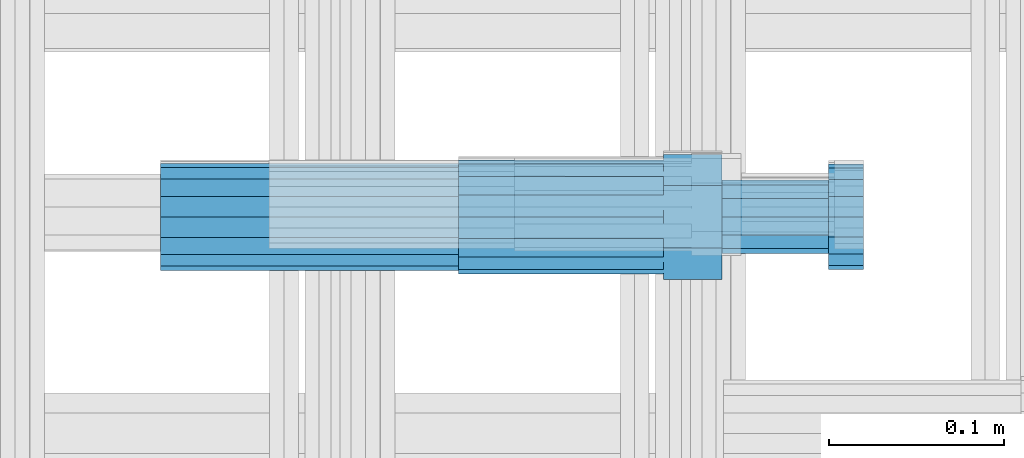
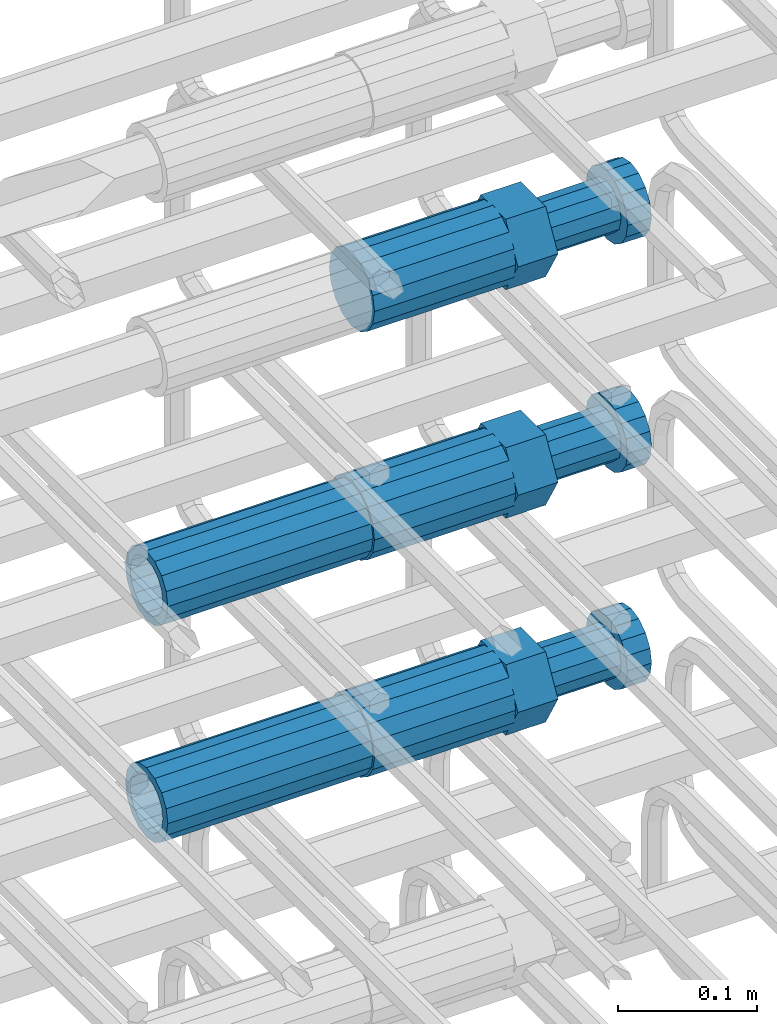
# One storey, part 46 of 177: 5 beams.
"""IFC2X3 building model written with IfcOpenShell, lengths in millimetres."""

from ifc_helpers import new_model, si_unit, frame, origin_with_axes, place, context, subcontext, project, spatial, faceted_brep, material, type_object, element, save


model = new_model("IFC2X3")

# Units and contexts
model_context_1 = context("Model", 3, precision=1e-05, world=origin_with_axes())
model_context_2 = context("Model", 3, precision=1e-05, world=origin_with_axes())
body_context = subcontext(model_context_2, "Body", "Model", "MODEL_VIEW")
ifc_project = project(units=[si_unit("LENGTHUNIT", "METRE", prefix="MILLI"), si_unit("AREAUNIT", "SQUARE_METRE"), si_unit("VOLUMEUNIT", "CUBIC_METRE"), si_unit("MASSUNIT", "GRAM", prefix="KILO"), si_unit("TIMEUNIT", "SECOND"), si_unit("PLANEANGLEUNIT", "RADIAN"), si_unit("SOLIDANGLEUNIT", "STERADIAN"), si_unit("THERMODYNAMICTEMPERATUREUNIT", "DEGREE_CELSIUS"), si_unit("LUMINOUSINTENSITYUNIT", "LUMEN")], contexts=[model_context_1])

# Site, building, storey
site_placement = place(None, origin_with_axes())
site = spatial("IfcSite", under=ifc_project, at=site_placement, CompositionType="ELEMENT")
building_placement = place(site_placement, origin_with_axes())
building = spatial("IfcBuilding", under=site, at=building_placement, Name="Undefined", CompositionType="ELEMENT")
storey_placement = place(building_placement, origin_with_axes())
storey = spatial("IfcBuildingStorey", under=building, at=storey_placement, Name="Undefined", CompositionType="ELEMENT", Elevation=0.0)

# Beams
ifc_material = material(Name="STEEL/S275")
beam_type_1 = type_object("IfcBeamType", PredefinedType="NOTDEFINED")
beam_1_placement = place(storey_placement, frame((2030819.00847313, 6206282.98588032, 21439.9868004324), z_axis=(0.0, 0.0, -1.0), x_axis=(1.0, 0.0, 0.0)))
element("IfcBeam", 1, at=beam_1_placement, inside=storey, type_object=beam_type_1, material=ifc_material, Name="AG40N", context=body_context, shape_type="Brep", body=[
    faceted_brep([(0.0, -23.5000000001164, -9.31322574615479e-10), (0.0, -21.7111690140155, 8.99306066054851), (170.0, -21.7111690140155, 8.99306066054851), (170.0, -23.5, 0.0), (0.0, -16.6170093578839, 16.6170093575493), (170.0, -16.6170093578839, 16.6170093575493), (0.0, -8.99306066057943, 21.7111690137535), (170.0, -8.99306066057943, 21.7111690137535), (0.0, 1.16415321826935e-10, 23.5), (170.0, 0.0, 23.5), (0.0, 8.99306066057943, 21.7111690137535), (170.0, 8.99306066057943, 21.7111690137535), (0.0, 16.6170093578839, 16.6170093575493), (170.0, 16.6170093578839, 16.6170093575493), (0.0, 21.7111690140155, 8.99306066054851), (170.0, 21.7111690140155, 8.99306066054851), (0.0, 23.5000000001164, -9.31322574615479e-10), (170.0, 23.5, 0.0), (0.0, 21.7111690140155, -8.99306066054851), (170.0, 21.7111690140155, -8.99306066054851), (0.0, 16.6170093578839, -16.6170093575493), (170.0, 16.6170093578839, -16.6170093575493), (0.0, 8.99306066057943, -21.7111690137535), (170.0, 8.99306066057943, -21.7111690137535), (0.0, 1.16415321826935e-10, -23.5000000009313), (170.0, 0.0, -23.5), (0.0, -8.99306066057943, -21.7111690137535), (170.0, -8.99306066057943, -21.7111690137535), (0.0, -16.6170093578839, -16.6170093575493), (170.0, -16.6170093578839, -16.6170093575493), (0.0, -21.7111690140155, -8.99306066054851), (170.0, -21.7111690140155, -8.99306066054851), (0.0, -30.5, 0.0), (0.0, -28.1783257415937, -11.6718446873128), (170.0, -28.1783257415937, -11.6718446873128), (170.0, -30.5, 0.0), (0.0, -21.5667568261888, -21.5667568258941), (170.0, -21.5667568261888, -21.5667568258941), (0.0, -11.6718446871346, -28.1783257415518), (170.0, -11.6718446871346, -28.1783257415518), (0.0, 0.0, -30.5), (170.0, 0.0, -30.5), (0.0, 11.6718446871346, -28.1783257415518), (170.0, 11.6718446871346, -28.1783257415518), (0.0, 21.5667568261888, -21.5667568258941), (170.0, 21.5667568261888, -21.5667568258941), (0.0, 28.1783257415937, -11.6718446873128), (170.0, 28.1783257415937, -11.6718446873128), (0.0, 30.5, 0.0), (170.0, 30.5, 0.0), (0.0, 28.1783257415937, 11.6718446873128), (170.0, 28.1783257415937, 11.6718446873128), (0.0, 21.5667568261888, 21.5667568258941), (170.0, 21.5667568261888, 21.5667568258941), (0.0, 11.6718446871346, 28.1783257415518), (170.0, 11.6718446871346, 28.1783257415518), (0.0, 0.0, 30.5), (170.0, 0.0, 30.5), (0.0, -11.6718446871346, 28.1783257415518), (170.0, -11.6718446871346, 28.1783257415518), (0.0, -21.5667568261888, 21.5667568258941), (170.0, -21.5667568261888, 21.5667568258941), (0.0, -28.1783257415937, 11.6718446873128), (170.0, -28.1783257415937, 11.6718446873128)], [[[0, 1, 2, 3]], [[1, 4, 5, 2]], [[4, 6, 7, 5]], [[6, 8, 9, 7]], [[8, 10, 11, 9]], [[10, 12, 13, 11]], [[12, 14, 15, 13]], [[14, 16, 17, 15]], [[16, 18, 19, 17]], [[18, 20, 21, 19]], [[20, 22, 23, 21]], [[22, 24, 25, 23]], [[24, 26, 27, 25]], [[26, 28, 29, 27]], [[28, 30, 31, 29]], [[30, 0, 3, 31]], [[32, 33, 34, 35]], [[33, 36, 37, 34]], [[36, 38, 39, 37]], [[38, 40, 41, 39]], [[40, 42, 43, 41]], [[42, 44, 45, 43]], [[44, 46, 47, 45]], [[46, 48, 49, 47]], [[48, 50, 51, 49]], [[50, 52, 53, 51]], [[52, 54, 55, 53]], [[54, 56, 57, 55]], [[56, 58, 59, 57]], [[58, 60, 61, 59]], [[60, 62, 63, 61]], [[62, 32, 35, 63]], [[37, 39, 41, 43, 45, 47, 49, 51, 53, 55, 57, 59, 61, 63, 35, 34], [5, 7, 9, 11, 13, 15, 17, 19, 21, 23, 25, 27, 29, 31, 3, 2]], [[62, 60, 58, 56, 54, 52, 50, 48, 46, 44, 42, 40, 38, 36, 33, 32], [30, 28, 26, 24, 22, 20, 18, 16, 14, 12, 10, 8, 6, 4, 1, 0]]]),
])
beam_2_placement = place(storey_placement, frame((2030819.00847313, 6206282.98588032, 21249.9868004324), z_axis=(0.0, 0.0, -1.0), x_axis=(1.0, 0.0, 0.0)))
element("IfcBeam", 2, at=beam_2_placement, inside=storey, type_object=beam_type_1, material=ifc_material, Name="AG40N", context=body_context, shape_type="Brep", body=[
    faceted_brep([(0.0, -23.5000000001164, -9.31322574615479e-10), (0.0, -21.7111690140155, 8.99306066054851), (170.0, -21.7111690140155, 8.99306066054851), (170.0, -23.5, 0.0), (0.0, -16.6170093578839, 16.6170093575493), (170.0, -16.6170093578839, 16.6170093575493), (0.0, -8.99306066057943, 21.7111690137535), (170.0, -8.99306066057943, 21.7111690137535), (0.0, 1.16415321826935e-10, 23.5), (170.0, 0.0, 23.5), (0.0, 8.99306066057943, 21.7111690137535), (170.0, 8.99306066057943, 21.7111690137535), (0.0, 16.6170093578839, 16.6170093575493), (170.0, 16.6170093578839, 16.6170093575493), (0.0, 21.7111690140155, 8.99306066054851), (170.0, 21.7111690140155, 8.99306066054851), (0.0, 23.5000000001164, -9.31322574615479e-10), (170.0, 23.5, 0.0), (0.0, 21.7111690140155, -8.99306066054851), (170.0, 21.7111690140155, -8.99306066054851), (0.0, 16.6170093578839, -16.6170093575493), (170.0, 16.6170093578839, -16.6170093575493), (0.0, 8.99306066057943, -21.7111690137535), (170.0, 8.99306066057943, -21.7111690137535), (0.0, 1.16415321826935e-10, -23.5000000009313), (170.0, 0.0, -23.5), (0.0, -8.99306066057943, -21.7111690137535), (170.0, -8.99306066057943, -21.7111690137535), (0.0, -16.6170093578839, -16.6170093575493), (170.0, -16.6170093578839, -16.6170093575493), (0.0, -21.7111690140155, -8.99306066054851), (170.0, -21.7111690140155, -8.99306066054851), (0.0, -30.5, 0.0), (0.0, -28.1783257415937, -11.6718446873128), (170.0, -28.1783257415937, -11.6718446873128), (170.0, -30.5, 0.0), (0.0, -21.5667568261888, -21.5667568258941), (170.0, -21.5667568261888, -21.5667568258941), (0.0, -11.6718446871346, -28.1783257415518), (170.0, -11.6718446871346, -28.1783257415518), (0.0, 0.0, -30.5), (170.0, 0.0, -30.5), (0.0, 11.6718446871346, -28.1783257415518), (170.0, 11.6718446871346, -28.1783257415518), (0.0, 21.5667568261888, -21.5667568258941), (170.0, 21.5667568261888, -21.5667568258941), (0.0, 28.1783257415937, -11.6718446873128), (170.0, 28.1783257415937, -11.6718446873128), (0.0, 30.5, 0.0), (170.0, 30.5, 0.0), (0.0, 28.1783257415937, 11.6718446873128), (170.0, 28.1783257415937, 11.6718446873128), (0.0, 21.5667568261888, 21.5667568258941), (170.0, 21.5667568261888, 21.5667568258941), (0.0, 11.6718446871346, 28.1783257415518), (170.0, 11.6718446871346, 28.1783257415518), (0.0, 0.0, 30.5), (170.0, 0.0, 30.5), (0.0, -11.6718446871346, 28.1783257415518), (170.0, -11.6718446871346, 28.1783257415518), (0.0, -21.5667568261888, 21.5667568258941), (170.0, -21.5667568261888, 21.5667568258941), (0.0, -28.1783257415937, 11.6718446873128), (170.0, -28.1783257415937, 11.6718446873128)], [[[0, 1, 2, 3]], [[1, 4, 5, 2]], [[4, 6, 7, 5]], [[6, 8, 9, 7]], [[8, 10, 11, 9]], [[10, 12, 13, 11]], [[12, 14, 15, 13]], [[14, 16, 17, 15]], [[16, 18, 19, 17]], [[18, 20, 21, 19]], [[20, 22, 23, 21]], [[22, 24, 25, 23]], [[24, 26, 27, 25]], [[26, 28, 29, 27]], [[28, 30, 31, 29]], [[30, 0, 3, 31]], [[32, 33, 34, 35]], [[33, 36, 37, 34]], [[36, 38, 39, 37]], [[38, 40, 41, 39]], [[40, 42, 43, 41]], [[42, 44, 45, 43]], [[44, 46, 47, 45]], [[46, 48, 49, 47]], [[48, 50, 51, 49]], [[50, 52, 53, 51]], [[52, 54, 55, 53]], [[54, 56, 57, 55]], [[56, 58, 59, 57]], [[58, 60, 61, 59]], [[60, 62, 63, 61]], [[62, 32, 35, 63]], [[37, 39, 41, 43, 45, 47, 49, 51, 53, 55, 57, 59, 61, 63, 35, 34], [5, 7, 9, 11, 13, 15, 17, 19, 21, 23, 25, 27, 29, 31, 3, 2]], [[62, 60, 58, 56, 54, 52, 50, 48, 46, 44, 42, 40, 38, 36, 33, 32], [30, 28, 26, 24, 22, 20, 18, 16, 14, 12, 10, 8, 6, 4, 1, 0]]]),
])
beam_type_2 = type_object("IfcBeamType", Name="ROD65", PredefinedType="NOTDEFINED")
beam_3_placement = place(storey_placement, frame((2030989.00847313, 6206282.98588032, 21639.9868004324), z_axis=(0.0, 0.0, -1.0), x_axis=(1.0, 0.0, 0.0)))
element("IfcBeam", 3, at=beam_3_placement, inside=storey, type_object=beam_type_2, material=ifc_material, Name="AGB40", ObjectType="ROD65", context=body_context, shape_type="Brep", body=[
    faceted_brep([(117.0, 8.17543110251427, 30.873805644922), (117.0, 17.8250000001863, 30.873805644922), (117.0, 22.0056958701462, 23.6326279877685), (117.0, 12.4372115517035, 30.0260848065373), (117.0, -17.8250000001863, 30.873805644922), (150.200000000186, -17.8250000001863, 30.873805644922), (150.200000000186, 17.8250000001863, 30.873805644922), (117.0, -8.17543110251427, 30.873805644922), (117.0, -12.4372115517035, 30.0260848065373), (117.0, -22.0056958701462, 23.6326279877685), (117.0, -35.6500000003725, 0.0), (150.200000000186, -35.6500000003725, 0.0), (117.0, -30.8443150008097, 8.32369058486074), (117.0, -32.5, 0.0), (117.0, -30.8443150008097, -8.32369058462791), (117.0, -17.8250000001863, -30.873805644922), (150.200000000186, -17.8250000001863, -30.873805644922), (117.0, -22.0056958701462, -23.6326279877685), (117.0, -12.4372115517035, -30.0260848065373), (117.0, -8.17543110251427, -30.873805644922), (117.0, 17.8250000001863, -30.873805644922), (150.200000000186, 17.8250000001863, -30.873805644922), (117.0, 8.17543110251427, -30.873805644922), (117.0, 22.0056958701462, -23.6326279877685), (117.0, 12.4372115517035, -30.0260848065373), (117.0, 35.6500000003725, 0.0), (150.200000000186, 35.6500000003725, 0.0), (117.0, 30.8443150008097, -8.32369058486074), (117.0, 30.8443150008097, 8.32369058462791), (117.0, 32.5, 0.0), (0.0, -22.9809703892097, 22.9809703885621), (0.0, -30.0260848058388, 12.4372115518636), (117.0, -30.0260848067701, 12.4372115519363), (117.0, -22.9809703882784, 22.9809703885112), (-2.3283064365387e-10, 22.9809703892097, -22.9809703885639), (-4.65661287307739e-10, 30.0260848077014, -12.4372115518672), (117.0, 30.0260848067701, -12.4372115519363), (117.0, 22.9809703882784, -22.9809703885112), (-2.3283064365387e-10, -30.0260848067701, -12.4372115518672), (-2.3283064365387e-10, -22.9809703892097, -22.9809703885621), (117.0, -22.9809703882784, -22.9809703885112), (117.0, -30.0260848067701, -12.4372115519363), (-2.3283064365387e-10, -12.4372115507722, 30.0260848066137), (-2.3283064365387e-10, 9.31322574615479e-10, 32.4999999999982), (-2.3283064365387e-10, 12.4372115526348, 30.0260848066137), (0.0, 22.9809703892097, 22.9809703885621), (-2.3283064365387e-10, 30.0260848077014, 12.4372115518636), (-2.3283064365387e-10, 32.5, 0.0), (-2.3283064365387e-10, 12.4372115526348, -30.0260848066173), (-2.3283064365387e-10, 9.31322574615479e-10, -32.5), (-2.3283064365387e-10, -12.4372115517035, -30.0260848066173), (-4.65661287307739e-10, -32.4999999990687, -1.81898940354586e-12), (117.0, 22.9809703882784, 22.9809703885112), (117.0, 30.0260848067701, 12.4372115519363), (117.0, 0.0, -32.5), (117.0, 0.0, 32.5), (150.200000000186, 10.5, -18.1865334794857), (150.200000000186, 0.0, -21.0), (150.200000000186, -10.5, -18.1865334794857), (150.200000000186, -18.18653347902, -10.5), (150.200000000186, -21.0, 0.0), (150.200000000186, -18.18653347902, 10.5), (150.200000000186, -10.5, 18.1865334794857), (150.200000000186, 0.0, 21.0), (150.200000000186, 10.5, 18.1865334794857), (150.200000000186, 18.18653347902, 10.5), (150.200000000186, 21.0, 0.0), (150.200000000186, 18.18653347902, -10.5), (210.980000000447, -18.18653347902, 10.5), (210.980000000447, -21.0, 0.0), (210.980000000447, -10.5, 18.1865334794857), (210.980000000447, 0.0, 21.0), (210.980000000447, 10.5, 18.1865334794857), (210.980000000447, 18.18653347902, 10.5), (210.980000000447, 21.0, 0.0), (210.980000000447, 18.18653347902, -10.5), (210.980000000447, 10.5, -18.1865334794857), (210.980000000447, 0.0, -21.0), (210.980000000447, -10.5, -18.1865334794857), (210.980000000447, -18.18653347902, -10.5), (211.001368442696, -27.7269937992096, -11.491116326768), (211.003082550167, -21.2238094303757, -21.223815418547), (231.002518367059, -21.2131944671273, -21.2132004550658), (231.000804259587, -27.7163788359612, -11.4805013632867), (211.001368440451, -11.4911085031927, -27.7269970395137), (231.000804257343, -11.4804935399443, -27.7163820760325), (210.996487071217, -0.0106065049767494, -30.0106107392348), (230.995922888109, 8.45827162265778e-06, -29.9999957757536), (210.989181586672, 11.46989420522, -27.7269970329944), (230.988617403564, 11.4805091684684, -27.7163820695132), (210.980564180623, 21.2025914648548, -21.2238154064398), (230.979999997515, 21.2132064281031, -21.2132004429586), (210.971946775022, 27.7057703435421, -11.4911163107026), (230.971382591913, 27.7163853067905, -11.4805013472214), (210.96464129175, 29.9893808094785, -0.0106149562634528), (230.964077108642, 29.9999957727268, 7.21774995326996e-09), (210.959759924415, 27.7057638689876, 11.4698863970116), (230.959195741307, 27.7163788322359, 11.4805013604928), (210.958045816944, 21.2025795001537, 21.2025854887906), (230.957481633835, 21.213194463402, 21.2132004522718), (210.95975992666, 11.4698785729706, 27.7057671097573), (230.959195743551, 11.480493536219, 27.7163820732385), (210.964641295894, -0.010623425245285, 29.9893808094785), (230.964077112785, -8.46199691295624e-06, 29.9999957729597), (210.971946780439, -11.4911241354421, 27.705767103238), (230.97138259733, -11.4805091721937, 27.7163820667192), (210.980564186488, -21.2238213950768, 21.2025854766835), (230.980000003379, -21.2132064318284, 21.2132004401647), (210.989181592089, -27.7270002737641, 11.4698863809463), (230.988617408981, -27.7163853105158, 11.4805013444275), (210.996487075361, -30.0106107397005, -0.0106149734929204), (230.995922892253, -29.9999957764521, -1.00117176771164e-08)], [[[0, 1, 2, 3]], [[4, 5, 6, 1, 0, 7]], [[4, 7, 8, 9]], [[10, 11, 5, 4, 9, 12]], [[10, 12, 13, 14]], [[15, 16, 11, 10, 14, 17]], [[15, 17, 18, 19]], [[20, 21, 16, 15, 19, 22]], [[23, 20, 22, 24]], [[25, 26, 21, 20, 23, 27]], [[28, 25, 27, 29]], [[30, 31, 32, 33]], [[34, 35, 36, 37]], [[38, 39, 40, 41]], [[31, 30, 42, 43, 44, 45, 46, 47, 35, 34, 48, 49, 50, 39, 38, 51]], [[46, 45, 52, 53]], [[29, 47, 46, 53, 28]], [[27, 36, 35, 47, 29]], [[23, 37, 36, 27]], [[24, 48, 34, 37, 23]], [[22, 54, 49, 48, 24]], [[19, 54, 22]], [[18, 50, 49, 54, 19]], [[17, 40, 39, 50, 18]], [[14, 41, 40, 17]], [[13, 51, 38, 41, 14]], [[12, 32, 31, 51, 13]], [[9, 33, 32, 12]], [[8, 42, 30, 33, 9]], [[7, 55, 43, 42, 8]], [[0, 55, 7]], [[3, 44, 43, 55, 0]], [[2, 52, 45, 44, 3]], [[28, 53, 52, 2]], [[1, 6, 26, 25, 28, 2]], [[5, 11, 16, 21, 26, 6], [56, 57, 58, 59, 60, 61, 62, 63, 64, 65, 66, 67]], [[68, 61, 60, 69]], [[70, 62, 61, 68]], [[71, 63, 62, 70]], [[72, 64, 63, 71]], [[73, 65, 64, 72]], [[74, 66, 65, 73]], [[75, 67, 66, 74]], [[76, 56, 67, 75]], [[77, 57, 56, 76]], [[78, 58, 57, 77]], [[79, 59, 58, 78]], [[69, 60, 59, 79]], [[80, 81, 82, 83]], [[81, 84, 85, 82]], [[84, 86, 87, 85]], [[86, 88, 89, 87]], [[88, 90, 91, 89]], [[90, 92, 93, 91]], [[92, 94, 95, 93]], [[94, 96, 97, 95]], [[96, 98, 99, 97]], [[98, 100, 101, 99]], [[100, 102, 103, 101]], [[102, 104, 105, 103]], [[104, 106, 107, 105]], [[106, 108, 109, 107]], [[108, 110, 111, 109]], [[82, 85, 87, 89, 91, 93, 95, 97, 99, 101, 103, 105, 107, 109, 111, 83]], [[110, 80, 83, 111]], [[108, 106, 104, 102, 100, 98, 96, 94, 92, 90, 88, 86, 84, 81, 80, 110], [75, 74, 73, 72, 71, 70, 68, 69, 79, 78, 77, 76]]]),
])
beam_4_placement = place(storey_placement, frame((2030989.00847313, 6206282.98588032, 21439.9868004324), z_axis=(0.0, 0.0, -1.0), x_axis=(1.0, 0.0, 0.0)))
element("IfcBeam", 4, at=beam_4_placement, inside=storey, type_object=beam_type_2, material=ifc_material, Name="AGB40", ObjectType="ROD65", context=body_context, shape_type="Brep", body=[
    faceted_brep([(117.0, 8.17543110251427, 30.873805644922), (117.0, 17.8250000001863, 30.873805644922), (117.0, 22.0056958701462, 23.6326279877685), (117.0, 12.4372115517035, 30.0260848065373), (117.0, -17.8250000001863, 30.873805644922), (150.200000000186, -17.8250000001863, 30.873805644922), (150.200000000186, 17.8250000001863, 30.873805644922), (117.0, -8.17543110251427, 30.873805644922), (117.0, -12.4372115517035, 30.0260848065373), (117.0, -22.0056958701462, 23.6326279877685), (117.0, -35.6500000003725, 0.0), (150.200000000186, -35.6500000003725, 0.0), (117.0, -30.8443150008097, 8.32369058486074), (117.0, -32.5, 0.0), (117.0, -30.8443150008097, -8.32369058462791), (117.0, -17.8250000001863, -30.873805644922), (150.200000000186, -17.8250000001863, -30.873805644922), (117.0, -22.0056958701462, -23.6326279877685), (117.0, -12.4372115517035, -30.0260848065373), (117.0, -8.17543110251427, -30.873805644922), (117.0, 17.8250000001863, -30.873805644922), (150.200000000186, 17.8250000001863, -30.873805644922), (117.0, 8.17543110251427, -30.873805644922), (117.0, 22.0056958701462, -23.6326279877685), (117.0, 12.4372115517035, -30.0260848065373), (117.0, 35.6500000003725, 0.0), (150.200000000186, 35.6500000003725, 0.0), (117.0, 30.8443150008097, -8.32369058486074), (117.0, 30.8443150008097, 8.32369058462791), (117.0, 32.5, 0.0), (0.0, -22.9809703892097, 22.9809703885621), (0.0, -30.0260848058388, 12.4372115518636), (117.0, -30.0260848067701, 12.4372115519363), (117.0, -22.9809703882784, 22.9809703885112), (-2.3283064365387e-10, 22.9809703892097, -22.9809703885639), (-4.65661287307739e-10, 30.0260848077014, -12.4372115518672), (117.0, 30.0260848067701, -12.4372115519363), (117.0, 22.9809703882784, -22.9809703885112), (-2.3283064365387e-10, -30.0260848067701, -12.4372115518672), (-2.3283064365387e-10, -22.9809703892097, -22.9809703885621), (117.0, -22.9809703882784, -22.9809703885112), (117.0, -30.0260848067701, -12.4372115519363), (-2.3283064365387e-10, -12.4372115507722, 30.0260848066137), (-2.3283064365387e-10, 9.31322574615479e-10, 32.4999999999982), (-2.3283064365387e-10, 12.4372115526348, 30.0260848066137), (0.0, 22.9809703892097, 22.9809703885621), (-2.3283064365387e-10, 30.0260848077014, 12.4372115518636), (-2.3283064365387e-10, 32.5, 0.0), (-2.3283064365387e-10, 12.4372115526348, -30.0260848066173), (-2.3283064365387e-10, 9.31322574615479e-10, -32.5), (-2.3283064365387e-10, -12.4372115517035, -30.0260848066173), (-4.65661287307739e-10, -32.4999999990687, -1.81898940354586e-12), (117.0, 22.9809703882784, 22.9809703885112), (117.0, 30.0260848067701, 12.4372115519363), (117.0, 0.0, -32.5), (117.0, 0.0, 32.5), (150.200000000186, 10.5, -18.1865334794857), (150.200000000186, 0.0, -21.0), (150.200000000186, -10.5, -18.1865334794857), (150.200000000186, -18.18653347902, -10.5), (150.200000000186, -21.0, 0.0), (150.200000000186, -18.18653347902, 10.5), (150.200000000186, -10.5, 18.1865334794857), (150.200000000186, 0.0, 21.0), (150.200000000186, 10.5, 18.1865334794857), (150.200000000186, 18.18653347902, 10.5), (150.200000000186, 21.0, 0.0), (150.200000000186, 18.18653347902, -10.5), (210.980000000447, -18.18653347902, 10.5), (210.980000000447, -21.0, 0.0), (210.980000000447, -10.5, 18.1865334794857), (210.980000000447, 0.0, 21.0), (210.980000000447, 10.5, 18.1865334794857), (210.980000000447, 18.18653347902, 10.5), (210.980000000447, 21.0, 0.0), (210.980000000447, 18.18653347902, -10.5), (210.980000000447, 10.5, -18.1865334794857), (210.980000000447, 0.0, -21.0), (210.980000000447, -10.5, -18.1865334794857), (210.980000000447, -18.18653347902, -10.5), (211.001368442696, -27.7269937992096, -11.491116326768), (211.003082550167, -21.2238094303757, -21.223815418547), (231.002518367059, -21.2131944671273, -21.2132004550658), (231.000804259587, -27.7163788359612, -11.4805013632867), (211.001368440451, -11.4911085031927, -27.7269970395137), (231.000804257343, -11.4804935399443, -27.7163820760325), (210.996487071217, -0.0106065049767494, -30.0106107392348), (230.995922888109, 8.45827162265778e-06, -29.9999957757536), (210.989181586672, 11.46989420522, -27.7269970329944), (230.988617403564, 11.4805091684684, -27.7163820695132), (210.980564180623, 21.2025914648548, -21.2238154064398), (230.979999997515, 21.2132064281031, -21.2132004429586), (210.971946775022, 27.7057703435421, -11.4911163107026), (230.971382591913, 27.7163853067905, -11.4805013472214), (210.96464129175, 29.9893808094785, -0.0106149562634528), (230.964077108642, 29.9999957727268, 7.21774995326996e-09), (210.959759924415, 27.7057638689876, 11.4698863970116), (230.959195741307, 27.7163788322359, 11.4805013604928), (210.958045816944, 21.2025795001537, 21.2025854887906), (230.957481633835, 21.213194463402, 21.2132004522718), (210.95975992666, 11.4698785729706, 27.7057671097573), (230.959195743551, 11.480493536219, 27.7163820732385), (210.964641295894, -0.010623425245285, 29.9893808094785), (230.964077112785, -8.46199691295624e-06, 29.9999957729597), (210.971946780439, -11.4911241354421, 27.705767103238), (230.97138259733, -11.4805091721937, 27.7163820667192), (210.980564186488, -21.2238213950768, 21.2025854766835), (230.980000003379, -21.2132064318284, 21.2132004401647), (210.989181592089, -27.7270002737641, 11.4698863809463), (230.988617408981, -27.7163853105158, 11.4805013444275), (210.996487075361, -30.0106107397005, -0.0106149734929204), (230.995922892253, -29.9999957764521, -1.00117176771164e-08)], [[[0, 1, 2, 3]], [[4, 5, 6, 1, 0, 7]], [[4, 7, 8, 9]], [[10, 11, 5, 4, 9, 12]], [[10, 12, 13, 14]], [[15, 16, 11, 10, 14, 17]], [[15, 17, 18, 19]], [[20, 21, 16, 15, 19, 22]], [[23, 20, 22, 24]], [[25, 26, 21, 20, 23, 27]], [[28, 25, 27, 29]], [[30, 31, 32, 33]], [[34, 35, 36, 37]], [[38, 39, 40, 41]], [[31, 30, 42, 43, 44, 45, 46, 47, 35, 34, 48, 49, 50, 39, 38, 51]], [[46, 45, 52, 53]], [[29, 47, 46, 53, 28]], [[27, 36, 35, 47, 29]], [[23, 37, 36, 27]], [[24, 48, 34, 37, 23]], [[22, 54, 49, 48, 24]], [[19, 54, 22]], [[18, 50, 49, 54, 19]], [[17, 40, 39, 50, 18]], [[14, 41, 40, 17]], [[13, 51, 38, 41, 14]], [[12, 32, 31, 51, 13]], [[9, 33, 32, 12]], [[8, 42, 30, 33, 9]], [[7, 55, 43, 42, 8]], [[0, 55, 7]], [[3, 44, 43, 55, 0]], [[2, 52, 45, 44, 3]], [[28, 53, 52, 2]], [[1, 6, 26, 25, 28, 2]], [[5, 11, 16, 21, 26, 6], [56, 57, 58, 59, 60, 61, 62, 63, 64, 65, 66, 67]], [[68, 61, 60, 69]], [[70, 62, 61, 68]], [[71, 63, 62, 70]], [[72, 64, 63, 71]], [[73, 65, 64, 72]], [[74, 66, 65, 73]], [[75, 67, 66, 74]], [[76, 56, 67, 75]], [[77, 57, 56, 76]], [[78, 58, 57, 77]], [[79, 59, 58, 78]], [[69, 60, 59, 79]], [[80, 81, 82, 83]], [[81, 84, 85, 82]], [[84, 86, 87, 85]], [[86, 88, 89, 87]], [[88, 90, 91, 89]], [[90, 92, 93, 91]], [[92, 94, 95, 93]], [[94, 96, 97, 95]], [[96, 98, 99, 97]], [[98, 100, 101, 99]], [[100, 102, 103, 101]], [[102, 104, 105, 103]], [[104, 106, 107, 105]], [[106, 108, 109, 107]], [[108, 110, 111, 109]], [[82, 85, 87, 89, 91, 93, 95, 97, 99, 101, 103, 105, 107, 109, 111, 83]], [[110, 80, 83, 111]], [[108, 106, 104, 102, 100, 98, 96, 94, 92, 90, 88, 86, 84, 81, 80, 110], [75, 74, 73, 72, 71, 70, 68, 69, 79, 78, 77, 76]]]),
])
beam_5_placement = place(storey_placement, frame((2030989.00847313, 6206282.98588032, 21249.9868004324), z_axis=(0.0, 0.0, -1.0), x_axis=(1.0, 0.0, 0.0)))
element("IfcBeam", 5, at=beam_5_placement, inside=storey, type_object=beam_type_2, material=ifc_material, Name="AGB40", ObjectType="ROD65", context=body_context, shape_type="Brep", body=[
    faceted_brep([(117.0, 8.17543110251427, 30.873805644922), (117.0, 17.8250000001863, 30.873805644922), (117.0, 22.0056958701462, 23.6326279877685), (117.0, 12.4372115517035, 30.0260848065373), (117.0, -17.8250000001863, 30.873805644922), (150.200000000186, -17.8250000001863, 30.873805644922), (150.200000000186, 17.8250000001863, 30.873805644922), (117.0, -8.17543110251427, 30.873805644922), (117.0, -12.4372115517035, 30.0260848065373), (117.0, -22.0056958701462, 23.6326279877685), (117.0, -35.6500000003725, 0.0), (150.200000000186, -35.6500000003725, 0.0), (117.0, -30.8443150008097, 8.32369058486074), (117.0, -32.5, 0.0), (117.0, -30.8443150008097, -8.32369058462791), (117.0, -17.8250000001863, -30.873805644922), (150.200000000186, -17.8250000001863, -30.873805644922), (117.0, -22.0056958701462, -23.6326279877685), (117.0, -12.4372115517035, -30.0260848065373), (117.0, -8.17543110251427, -30.873805644922), (117.0, 17.8250000001863, -30.873805644922), (150.200000000186, 17.8250000001863, -30.873805644922), (117.0, 8.17543110251427, -30.873805644922), (117.0, 22.0056958701462, -23.6326279877685), (117.0, 12.4372115517035, -30.0260848065373), (117.0, 35.6500000003725, 0.0), (150.200000000186, 35.6500000003725, 0.0), (117.0, 30.8443150008097, -8.32369058486074), (117.0, 30.8443150008097, 8.32369058462791), (117.0, 32.5, 0.0), (0.0, -22.9809703892097, 22.9809703885621), (0.0, -30.0260848058388, 12.4372115518636), (117.0, -30.0260848067701, 12.4372115519363), (117.0, -22.9809703882784, 22.9809703885112), (-2.3283064365387e-10, 22.9809703892097, -22.9809703885639), (-4.65661287307739e-10, 30.0260848077014, -12.4372115518672), (117.0, 30.0260848067701, -12.4372115519363), (117.0, 22.9809703882784, -22.9809703885112), (-2.3283064365387e-10, -30.0260848067701, -12.4372115518672), (-2.3283064365387e-10, -22.9809703892097, -22.9809703885621), (117.0, -22.9809703882784, -22.9809703885112), (117.0, -30.0260848067701, -12.4372115519363), (-2.3283064365387e-10, -12.4372115507722, 30.0260848066137), (-2.3283064365387e-10, 9.31322574615479e-10, 32.4999999999982), (-2.3283064365387e-10, 12.4372115526348, 30.0260848066137), (0.0, 22.9809703892097, 22.9809703885621), (-2.3283064365387e-10, 30.0260848077014, 12.4372115518636), (-2.3283064365387e-10, 32.5, 0.0), (-2.3283064365387e-10, 12.4372115526348, -30.0260848066173), (-2.3283064365387e-10, 9.31322574615479e-10, -32.5), (-2.3283064365387e-10, -12.4372115517035, -30.0260848066173), (-4.65661287307739e-10, -32.4999999990687, -1.81898940354586e-12), (117.0, 22.9809703882784, 22.9809703885112), (117.0, 30.0260848067701, 12.4372115519363), (117.0, 0.0, -32.5), (117.0, 0.0, 32.5), (150.200000000186, 10.5, -18.1865334794857), (150.200000000186, 0.0, -21.0), (150.200000000186, -10.5, -18.1865334794857), (150.200000000186, -18.18653347902, -10.5), (150.200000000186, -21.0, 0.0), (150.200000000186, -18.18653347902, 10.5), (150.200000000186, -10.5, 18.1865334794857), (150.200000000186, 0.0, 21.0), (150.200000000186, 10.5, 18.1865334794857), (150.200000000186, 18.18653347902, 10.5), (150.200000000186, 21.0, 0.0), (150.200000000186, 18.18653347902, -10.5), (210.980000000447, -18.18653347902, 10.5), (210.980000000447, -21.0, 0.0), (210.980000000447, -10.5, 18.1865334794857), (210.980000000447, 0.0, 21.0), (210.980000000447, 10.5, 18.1865334794857), (210.980000000447, 18.18653347902, 10.5), (210.980000000447, 21.0, 0.0), (210.980000000447, 18.18653347902, -10.5), (210.980000000447, 10.5, -18.1865334794857), (210.980000000447, 0.0, -21.0), (210.980000000447, -10.5, -18.1865334794857), (210.980000000447, -18.18653347902, -10.5), (211.001368442696, -27.7269937992096, -11.491116326768), (211.003082550167, -21.2238094303757, -21.223815418547), (231.002518367059, -21.2131944671273, -21.2132004550658), (231.000804259587, -27.7163788359612, -11.4805013632867), (211.001368440451, -11.4911085031927, -27.7269970395137), (231.000804257343, -11.4804935399443, -27.7163820760325), (210.996487071217, -0.0106065049767494, -30.0106107392348), (230.995922888109, 8.45827162265778e-06, -29.9999957757536), (210.989181586672, 11.46989420522, -27.7269970329944), (230.988617403564, 11.4805091684684, -27.7163820695132), (210.980564180623, 21.2025914648548, -21.2238154064398), (230.979999997515, 21.2132064281031, -21.2132004429586), (210.971946775022, 27.7057703435421, -11.4911163107026), (230.971382591913, 27.7163853067905, -11.4805013472214), (210.96464129175, 29.9893808094785, -0.0106149562634528), (230.964077108642, 29.9999957727268, 7.21774995326996e-09), (210.959759924415, 27.7057638689876, 11.4698863970116), (230.959195741307, 27.7163788322359, 11.4805013604928), (210.958045816944, 21.2025795001537, 21.2025854887906), (230.957481633835, 21.213194463402, 21.2132004522718), (210.95975992666, 11.4698785729706, 27.7057671097573), (230.959195743551, 11.480493536219, 27.7163820732385), (210.964641295894, -0.010623425245285, 29.9893808094785), (230.964077112785, -8.46199691295624e-06, 29.9999957729597), (210.971946780439, -11.4911241354421, 27.705767103238), (230.97138259733, -11.4805091721937, 27.7163820667192), (210.980564186488, -21.2238213950768, 21.2025854766835), (230.980000003379, -21.2132064318284, 21.2132004401647), (210.989181592089, -27.7270002737641, 11.4698863809463), (230.988617408981, -27.7163853105158, 11.4805013444275), (210.996487075361, -30.0106107397005, -0.0106149734929204), (230.995922892253, -29.9999957764521, -1.00117176771164e-08)], [[[0, 1, 2, 3]], [[4, 5, 6, 1, 0, 7]], [[4, 7, 8, 9]], [[10, 11, 5, 4, 9, 12]], [[10, 12, 13, 14]], [[15, 16, 11, 10, 14, 17]], [[15, 17, 18, 19]], [[20, 21, 16, 15, 19, 22]], [[23, 20, 22, 24]], [[25, 26, 21, 20, 23, 27]], [[28, 25, 27, 29]], [[30, 31, 32, 33]], [[34, 35, 36, 37]], [[38, 39, 40, 41]], [[31, 30, 42, 43, 44, 45, 46, 47, 35, 34, 48, 49, 50, 39, 38, 51]], [[46, 45, 52, 53]], [[29, 47, 46, 53, 28]], [[27, 36, 35, 47, 29]], [[23, 37, 36, 27]], [[24, 48, 34, 37, 23]], [[22, 54, 49, 48, 24]], [[19, 54, 22]], [[18, 50, 49, 54, 19]], [[17, 40, 39, 50, 18]], [[14, 41, 40, 17]], [[13, 51, 38, 41, 14]], [[12, 32, 31, 51, 13]], [[9, 33, 32, 12]], [[8, 42, 30, 33, 9]], [[7, 55, 43, 42, 8]], [[0, 55, 7]], [[3, 44, 43, 55, 0]], [[2, 52, 45, 44, 3]], [[28, 53, 52, 2]], [[1, 6, 26, 25, 28, 2]], [[5, 11, 16, 21, 26, 6], [56, 57, 58, 59, 60, 61, 62, 63, 64, 65, 66, 67]], [[68, 61, 60, 69]], [[70, 62, 61, 68]], [[71, 63, 62, 70]], [[72, 64, 63, 71]], [[73, 65, 64, 72]], [[74, 66, 65, 73]], [[75, 67, 66, 74]], [[76, 56, 67, 75]], [[77, 57, 56, 76]], [[78, 58, 57, 77]], [[79, 59, 58, 78]], [[69, 60, 59, 79]], [[80, 81, 82, 83]], [[81, 84, 85, 82]], [[84, 86, 87, 85]], [[86, 88, 89, 87]], [[88, 90, 91, 89]], [[90, 92, 93, 91]], [[92, 94, 95, 93]], [[94, 96, 97, 95]], [[96, 98, 99, 97]], [[98, 100, 101, 99]], [[100, 102, 103, 101]], [[102, 104, 105, 103]], [[104, 106, 107, 105]], [[106, 108, 109, 107]], [[108, 110, 111, 109]], [[82, 85, 87, 89, 91, 93, 95, 97, 99, 101, 103, 105, 107, 109, 111, 83]], [[110, 80, 83, 111]], [[108, 106, 104, 102, 100, 98, 96, 94, 92, 90, 88, 86, 84, 81, 80, 110], [75, 74, 73, 72, 71, 70, 68, 69, 79, 78, 77, 76]]]),
])

save(model, "model.ifc")
